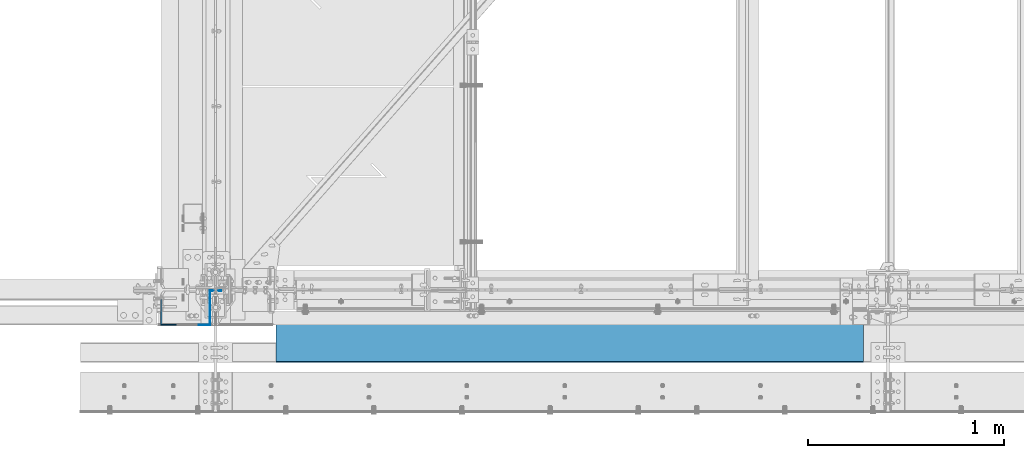
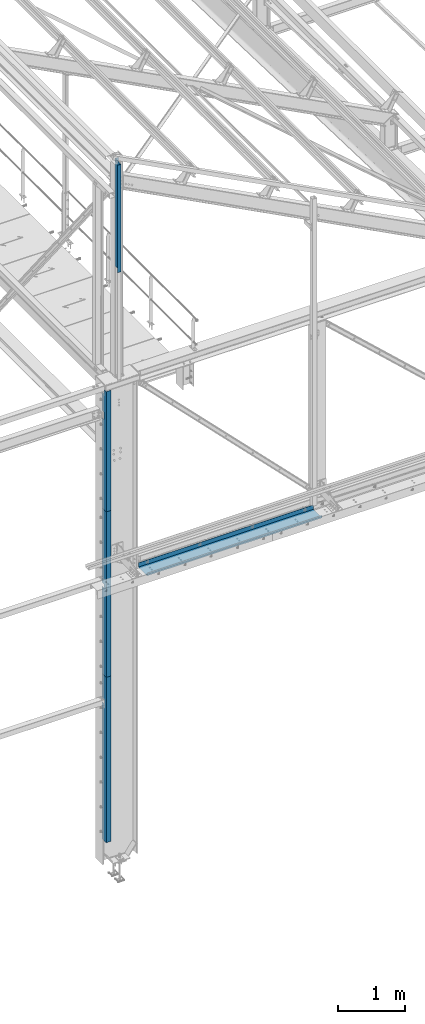
# One storey, part 343 of 496: 5 beams, 5 elements without a shape of their own.
"""IFC2X3 building model written with IfcOpenShell, lengths in millimetres."""

from ifc_helpers import new_model, si_unit, frame, origin_with_axes, place, context, subcontext, project, spatial, faceted_brep, material, type_object, element, aggregate, save


model = new_model("IFC2X3")

# Units and contexts
model_context = context("Model", 3, precision=1e-05, world=origin_with_axes())
body_context = subcontext(model_context, "Body", "Model", "MODEL_VIEW")
ifc_project = project(units=[si_unit("LENGTHUNIT", "METRE", prefix="MILLI"), si_unit("AREAUNIT", "SQUARE_METRE"), si_unit("VOLUMEUNIT", "CUBIC_METRE"), si_unit("MASSUNIT", "GRAM", prefix="KILO"), si_unit("TIMEUNIT", "SECOND"), si_unit("PLANEANGLEUNIT", "RADIAN"), si_unit("SOLIDANGLEUNIT", "STERADIAN"), si_unit("THERMODYNAMICTEMPERATUREUNIT", "DEGREE_CELSIUS"), si_unit("LUMINOUSINTENSITYUNIT", "LUMEN")], contexts=[model_context])

# Site, building, storey
site_placement = place(None, origin_with_axes())
site = spatial("IfcSite", under=ifc_project, at=site_placement, CompositionType="ELEMENT")
building_placement = place(site_placement, origin_with_axes())
building = spatial("IfcBuilding", under=site, at=building_placement, Name="Undefined", CompositionType="ELEMENT")
storey_placement = place(building_placement, origin_with_axes())
storey = spatial("IfcBuildingStorey", under=building, at=storey_placement, Name="Undefined", CompositionType="ELEMENT", Elevation=0.0)

# Assembly, beam
assembly_1_placement = place(storey_placement, origin_with_axes())
assembly_1 = element("IfcElementAssembly", 1, at=assembly_1_placement, inside=storey, Name="SUPPORT", AssemblyPlace="NOTDEFINED", PredefinedType="NOTDEFINED")
ifc_material = material(Name="Undefined/S235-E24")
beam_type_1 = type_object("IfcBeamType", PredefinedType="NOTDEFINED")
beam_1_placement = place(assembly_1_placement, frame((14489.9999999585, -111.5, 5080.00085614788), z_axis=(1.0, 0.0, 0.0), x_axis=(0.0, 0.0, -1.0)))
beam_1 = element("IfcBeam", 2, at=beam_1_placement, type_object=beam_type_1, material=ifc_material, Name="SUPPORT", context=body_context, shape_type="Brep", body=[
    faceted_brep([(0.0, -1.5, -1500.0), (0.0, -1.5, 1500.0), (0.0, 1.5, 1500.0), (0.0, 1.5, -1500.0), (80.0, 1.5, 1500.0), (80.0, 1.5, -1500.0), (77.0, -1.5, -1500.0), (77.0, -1.5, 1500.0), (80.0, -258.5, 1500.0), (80.0, -258.5, -1500.0), (77.0, -255.5, -1500.0), (77.0, -255.5, 1500.0), (30.0000019073486, -258.5, 1500.0), (30.0000019073486, -258.5, -1500.0), (30.0000019073486, -255.5, 1500.0), (30.0000019073486, -255.5, -1500.0)], [[[0, 1, 2, 3]], [[3, 2, 4, 5]], [[1, 0, 6, 7]], [[5, 4, 8, 9]], [[7, 6, 10, 11]], [[9, 8, 12, 13]], [[8, 4, 2, 1, 7, 11, 14, 12]], [[11, 10, 15, 14]], [[10, 6, 0, 3, 5, 9, 13, 15]], [[14, 15, 13, 12]]]),
])
aggregate(assembly_1, [beam_1])

assembly_2_placement = place(storey_placement, origin_with_axes())
assembly_2 = element("IfcElementAssembly", 3, at=assembly_2_placement, inside=storey, AssemblyPlace="NOTDEFINED", PredefinedType="NOTDEFINED")
beam_type_2 = type_object("IfcBeamType", PredefinedType="NOTDEFINED")
beam_2_placement = place(assembly_2_placement, frame((12479.0000332611, -177.499999406672, 7340.0000156157), z_axis=(0.0, 0.0, 1.0), x_axis=(-1.0, 0.0, 0.0)))
beam_2 = element("IfcBeam", 4, at=beam_2_placement, type_object=beam_type_2, material=ifc_material, context=body_context, shape_type="Brep", body=[
    faceted_brep([(75.0000295613881, -127.499991191965, 539.998718261718), (80.0000295613881, -127.500000605994, 539.998718261718), (80.0000299813892, -67.4999999666719, 539.998718261718), (75.0000299813892, -67.4999999316719, 539.998718261718), (80.0000299813892, -67.4999999666719, 679.999999999999), (75.0000299813892, -67.4999999316719, 679.999999999999), (75.0000295613881, -127.499999931672, 679.999999999999), (80.0000295613881, -127.500000605994, 679.999999999999), (-1.04046193882823e-09, -2.50000000000003, -1090.0), (-1.04046193882823e-09, -2.50000000000003, 1090.0), (1.04409991763532e-09, 2.49999999999997, 1090.0), (1.04409991763532e-09, 2.49999999999997, -1090.0), (80.0000304713867, 2.50000003341538, 1090.0), (80.0000304713867, 2.50000003341538, -1090.0), (75.0000304363875, -2.49999996867308, -1090.0), (80.0000295613881, -127.500000605994, -1090.0), (75.0000295613881, -127.500000570994, -1090.0), (75.0000304363875, -2.49999996867308, 1090.0), (75.0000299813873, -67.4999999316719, 1090.0), (80.0000299813873, -67.4999999666719, 1090.0), (75.0000299813873, -67.4999999316719, 1009.99871063232), (80.0000299813873, -67.4999999666719, 1009.99871063232), (75.0000295613881, -127.49998848758, 1009.99871063232), (80.0000295613881, -127.500000605994, 1009.99871063232)], [[[0, 1, 2, 3]], [[3, 2, 4, 5]], [[6, 5, 4, 7]], [[8, 9, 10, 11]], [[11, 10, 12, 13]], [[14, 8, 11, 13, 15, 16]], [[9, 8, 14, 17]], [[12, 10, 9, 17, 18, 19]], [[18, 20, 21, 19]], [[22, 23, 21, 20]], [[23, 22, 6, 7]], [[2, 1, 15, 13, 12, 19, 21, 23, 7, 4]], [[16, 15, 1, 0]], [[22, 20, 18, 17, 14, 16, 0, 3, 5, 6]]]),
])
aggregate(assembly_2, [beam_2])

assembly_3_placement = place(storey_placement, origin_with_axes())
assembly_3 = element("IfcElementAssembly", 5, at=assembly_3_placement, inside=storey, AssemblyPlace="NOTDEFINED", PredefinedType="NOTDEFINED")
beam_type_3 = type_object("IfcBeamType", PredefinedType="NOTDEFINED")
beam_3_placement = place(assembly_3_placement, frame((12479.0000322799, -177.499999406672, 4750.0000156124), z_axis=(0.0, 0.0, 1.0), x_axis=(-1.0, 0.0, 0.0)))
beam_3 = element("IfcBeam", 6, at=beam_3_placement, type_object=beam_type_3, material=ifc_material, context=body_context, shape_type="Brep", body=[
    faceted_brep([(75.0000295444279, -127.500000587954, 79.99218047872), (80.0000295444279, -127.500000622954, 79.99218047872), (80.0000299644271, -67.4999919172369, 79.99218047872), (75.0000299644271, -67.4999918822369, 79.99218047872), (80.0000299644271, -67.4999919172369, 149.99218047872), (75.0000299644271, -67.4999918822369, 149.99218047872), (75.0000295444279, -127.499991882239, 149.99218047872), (80.0000295444279, -127.500000622954, 149.99218047872), (-1.04046193882823e-09, -2.5, -1500.0), (-1.04046193882823e-09, -2.5, 1500.0), (1.04409991763532e-09, 2.5, 1500.0), (1.04409991763532e-09, 2.5, -1500.0), (80.0000304544265, 2.50000003341535, 1500.0), (80.0000304544265, 2.50000003341535, -1500.0), (75.0000304194273, -2.49999996867311, -1500.0), (80.0000295444279, -127.500000622954, -1500.0), (75.0000295444279, -127.500000587954, -1500.0), (75.0000304194273, -2.49999996867311, 1500.0), (75.0000295444279, -127.500000587954, 1500.0), (80.0000295444279, -127.500000622954, 1500.0)], [[[0, 1, 2, 3]], [[3, 2, 4, 5]], [[6, 5, 4, 7]], [[8, 9, 10, 11]], [[11, 10, 12, 13]], [[14, 8, 11, 13, 15, 16]], [[9, 8, 14, 17]], [[12, 10, 9, 17, 18, 19]], [[19, 18, 6, 7]], [[2, 1, 15, 13, 12, 19, 7, 4]], [[16, 15, 1, 0]], [[18, 17, 14, 16, 0, 3, 5, 6]]]),
])
aggregate(assembly_3, [beam_3])

assembly_4_placement = place(storey_placement, origin_with_axes())
assembly_4 = element("IfcElementAssembly", 7, at=assembly_4_placement, inside=storey, AssemblyPlace="NOTDEFINED", PredefinedType="NOTDEFINED")
beam_4_placement = place(assembly_4_placement, frame((12479.0000313156, -177.499999406672, 1750.00001560909), z_axis=(0.0, 0.0, 1.0), x_axis=(-1.0, 0.0, 0.0)))
beam_4 = element("IfcBeam", 8, at=beam_4_placement, type_object=beam_type_3, material=ifc_material, context=body_context, shape_type="Brep", body=[
    faceted_brep([(75.0000295444279, -127.500000587954, 979.996082436471), (80.0000295444279, -127.500000622954, 979.996082436471), (80.0000299644271, -67.5000006229541, 979.996082436471), (75.0000299644271, -67.5000005879541, 979.996082436471), (80.0000299644271, -67.5000006229541, 1049.99608243647), (75.0000299644271, -67.5000005879541, 1049.99608243647), (75.0000295444279, -127.500000587957, 1049.99608243647), (80.0000295444279, -127.500000622954, 1049.99608243647), (-1.04046193882823e-09, -2.5, -1500.0), (-1.04046193882823e-09, -2.5, 1500.0), (1.04409991763532e-09, 2.5, 1500.0), (1.04409991763532e-09, 2.5, -1500.0), (80.0000304544265, 2.50000003341535, 1500.0), (80.0000304544265, 2.50000003341535, -1500.0), (75.0000304194273, -2.49999996867311, -1500.0), (80.0000295444279, -127.500000622954, -1500.0), (75.0000295444279, -127.500000587954, -1500.0), (75.0000304194273, -2.49999996867311, 1500.0), (75.0000295444279, -127.500000587954, 1500.0), (80.0000295444279, -127.500000622954, 1500.0)], [[[0, 1, 2, 3]], [[3, 2, 4, 5]], [[6, 5, 4, 7]], [[8, 9, 10, 11]], [[11, 10, 12, 13]], [[14, 8, 11, 13, 15, 16]], [[9, 8, 14, 17]], [[12, 10, 9, 17, 18, 19]], [[19, 18, 6, 7]], [[2, 1, 15, 13, 12, 19, 7, 4]], [[16, 15, 1, 0]], [[18, 17, 14, 16, 0, 3, 5, 6]]]),
])
aggregate(assembly_4, [beam_4])

assembly_5_placement = place(storey_placement, origin_with_axes())
assembly_5 = element("IfcElementAssembly", 9, at=assembly_5_placement, inside=storey, AssemblyPlace="NOTDEFINED", PredefinedType="NOTDEFINED")
beam_type_4 = type_object("IfcBeamType", PredefinedType="NOTDEFINED")
beam_5_placement = place(assembly_5_placement, frame((12710.0000002043, -4.25, 11495.0000000118), z_axis=(0.0, 0.0, 1.0), x_axis=(-1.0, 0.0, 0.0)))
beam_5 = element("IfcBeam", 10, at=beam_5_placement, type_object=beam_type_4, material=ifc_material, context=body_context, shape_type="Brep", body=[
    faceted_brep([(0.0, -1.5, -975.0), (0.0, -1.5, 975.0), (0.0, 1.5, 975.0), (0.0, 1.5, -975.0), (56.9999998723069, 1.5, 975.0), (56.9999998723069, 1.5, -975.0), (59.9999998723069, -1.5, -975.0), (59.9999998723069, -1.5, 975.0), (56.9999998723069, 175.75, 975.0), (56.9999998723069, 175.75, -975.0), (59.9999998723069, 172.75, -975.0), (59.9999998723069, 172.75, 975.0), (117.0, 175.75, 975.0), (117.0, 175.75, -975.0), (117.0, 172.75, 975.0), (117.0, 172.75, -975.0)], [[[0, 1, 2, 3]], [[3, 2, 4, 5]], [[1, 0, 6, 7]], [[5, 4, 8, 9]], [[7, 6, 10, 11]], [[9, 8, 12, 13]], [[8, 4, 2, 1, 7, 11, 14, 12]], [[11, 10, 15, 14]], [[10, 6, 0, 3, 5, 9, 13, 15]], [[14, 15, 13, 12]]]),
])
aggregate(assembly_5, [beam_5])

save(model, "model.ifc")
